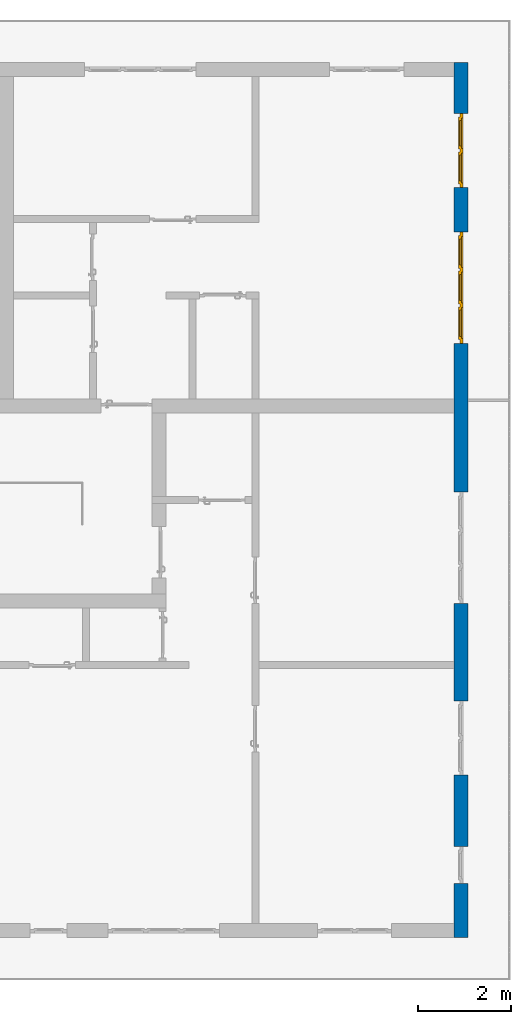
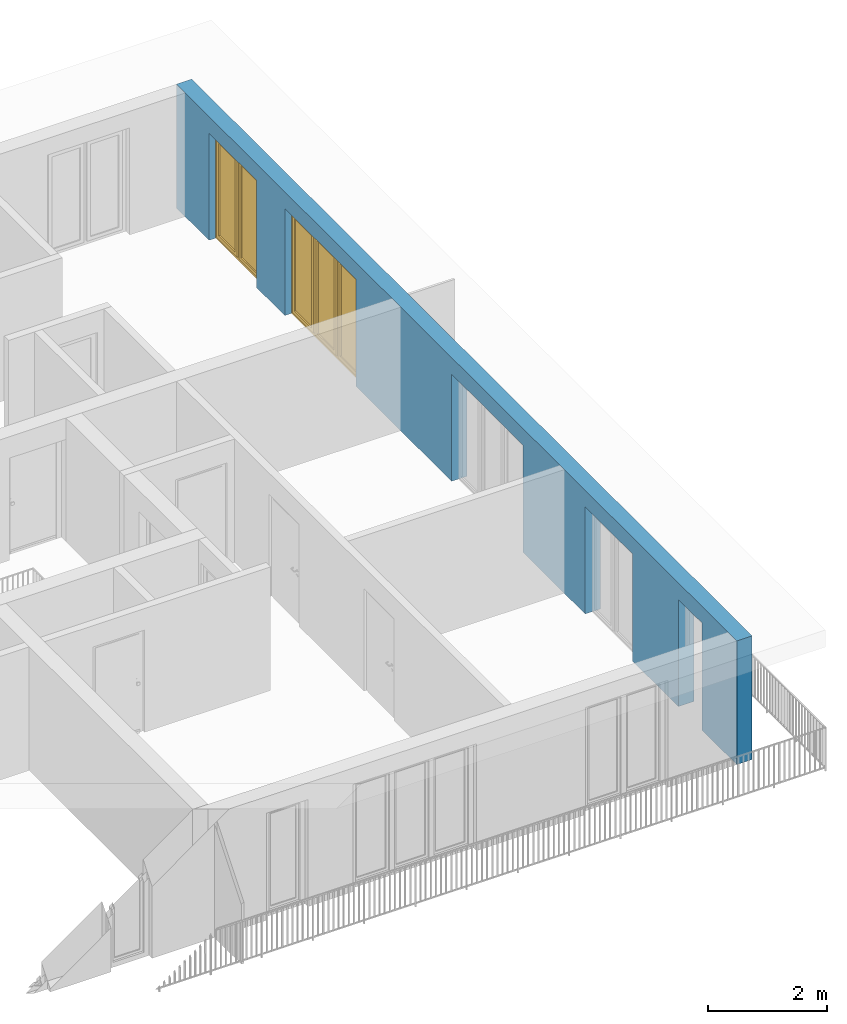
# One storey, part 21 of 54: 2 windows, 1 wall, 5 openings.
"""IFC4 building model written with IfcOpenShell, lengths in metres."""

import ifcopenshell
import ifcopenshell.guid

model = None  # the IFC model being written
_history = None  # IfcOwnerHistory: only IFC2X3 demands one
_inside = {}  # id of a spatial element -> (the spatial element, [elements in it])
_under = {}  # id of a project, library or spatial element -> (it, [spatial elements below it])
_declared = {}  # id of a project -> (the project, [libraries it declares])
_typed = {}  # id of a type object -> (the type object, [elements of that type])
_made_of = {}  # id of a material, layer set ... -> (it, [elements and type objects made of it])


def new_model(schema):
    """Start an empty IFC model of exactly this schema.

    Asked for "IFC4X3", IfcOpenShell would pick the latest addendum, in which some entities
    have other attributes; the version numbers below select the first issue.
    IFC2X3 requires an IfcOwnerHistory on every rooted entity: one is made here for all.
    """
    global model, _history
    if schema == "IFC4X3":
        model = ifcopenshell.file(schema_version=(4, 3, 0, 0))
    else:
        model = ifcopenshell.file(schema=schema)
    _inside.clear()
    _under.clear()
    _declared.clear()
    _typed.clear()
    _made_of.clear()
    _history = None
    if model.schema == "IFC2X3":
        org = make("IfcOrganization", Name="unknown")
        user = make(
            "IfcPersonAndOrganization",
            ThePerson=make("IfcPerson", FamilyName="unknown"),
            TheOrganization=org,
        )
        app = make(
            "IfcApplication",
            ApplicationDeveloper=org,
            Version="unknown",
            ApplicationFullName="unknown",
            ApplicationIdentifier="unknown",
        )
        _history = make(
            "IfcOwnerHistory",
            OwningUser=user,
            OwningApplication=app,
            ChangeAction="ADDED",
            CreationDate=0,
        )
    return model


def make(cls, **values):
    """One entity of the class cls with the attributes given. An attribute that is None is left unset."""
    return model.create_entity(
        cls, **{name: value for name, value in values.items() if value is not None}
    )


def entity(cls, *values):
    """Any entity or typed value of the class cls, its attributes in the order of the schema. None: left unset."""
    e = model.create_entity(cls)
    for i, value in enumerate(values):
        if value is not None:
            e[i] = value
    return e


def rooted(cls, **values):
    """An entity with a GlobalId (a new one), such as an element, a storey or a relation."""
    return make(cls, GlobalId=ifcopenshell.guid.new(), OwnerHistory=_history, **values)


def si_unit(unit_type, name, prefix=None):
    """IfcSIUnit, for example si_unit("LENGTHUNIT", "METRE", prefix="MILLI")."""
    return make("IfcSIUnit", UnitType=unit_type, Prefix=prefix, Name=name)


def converted_unit(unit_type, name, factor, base, dimensions=None, offset=None):
    """IfcConversionBasedUnit, such as the inch: factor (a typed value) times the base unit."""
    return make(
        "IfcConversionBasedUnit"
        if offset is None
        else "IfcConversionBasedUnitWithOffset",
        ConversionOffset=offset,
        Dimensions=None
        if dimensions is None
        else entity("IfcDimensionalExponents", *dimensions),
        UnitType=unit_type,
        Name=name,
        ConversionFactor=make(
            "IfcMeasureWithUnit", ValueComponent=factor, UnitComponent=base
        ),
    )


def derived_unit(unit_type, elements):
    """IfcDerivedUnit: a product of units, each with its exponent."""
    return make(
        "IfcDerivedUnit",
        Elements=[
            make("IfcDerivedUnitElement", Unit=unit, Exponent=power)
            for unit, power in elements
        ],
        UnitType=unit_type,
    )


def assignment(units):
    """IfcUnitAssignment: the units of a project."""
    return None if units is None else make("IfcUnitAssignment", Units=units)


def point(xyz):
    """IfcCartesianPoint."""
    return None if xyz is None else make("IfcCartesianPoint", Coordinates=xyz)


def direction(xyz):
    """IfcDirection."""
    return None if xyz is None else make("IfcDirection", DirectionRatios=xyz)


def frame(location, z_axis=None, x_axis=None):
    """IfcAxis2Placement3D, a coordinate frame: its origin and axes. An axis left out is left unset."""
    return make(
        "IfcAxis2Placement3D",
        Location=point(location),
        Axis=direction(z_axis),
        RefDirection=direction(x_axis),
    )


def origin_with_axes():
    """The frame at (0, 0, 0) with the z axis (0, 0, 1) and the x axis (1, 0, 0) written out."""
    return frame((0.0, 0.0, 0.0), z_axis=(0.0, 0.0, 1.0), x_axis=(1.0, 0.0, 0.0))


def place(relative_to, where):
    """IfcLocalPlacement: puts the frame where relative to a parent placement (None: the world)."""
    return make(
        "IfcLocalPlacement", PlacementRelTo=relative_to, RelativePlacement=where
    )


def context(
    kind, dimensions, precision=None, world=None, true_north=None, identifier=None
):
    """IfcGeometricRepresentationContext, for example the 3D "Model" context."""
    return make(
        "IfcGeometricRepresentationContext",
        ContextIdentifier=identifier,
        ContextType=kind,
        CoordinateSpaceDimension=dimensions,
        Precision=precision,
        WorldCoordinateSystem=world,
        TrueNorth=true_north,
    )


def subcontext(parent, identifier, kind, view, scale=None):
    """IfcGeometricRepresentationSubContext, for example "Body" below "Model"."""
    return make(
        "IfcGeometricRepresentationSubContext",
        ContextIdentifier=identifier,
        ContextType=kind,
        ParentContext=parent,
        TargetScale=scale,
        TargetView=view,
    )


def project(units=None, contexts=None):
    """IfcProject with its units and contexts."""
    return rooted(
        "IfcProject",
        Name="project",
        RepresentationContexts=contexts,
        UnitsInContext=assignment(units),
    )


def spatial(cls, under=None, at=None, **own):
    """A site, building, storey or space (cls), placed at a placement, below another one or the project."""
    s = rooted(cls, ObjectPlacement=at, **own)
    if under is not None:
        _under.setdefault(under.id(), (under, []))[1].append(s)
    return s


def point_list(points):
    """IfcCartesianPointList2D or 3D."""
    cls = (
        "IfcCartesianPointList2D" if len(points[0]) == 2 else "IfcCartesianPointList3D"
    )
    return make(cls, CoordList=points)


def polygons(points, faces, closed=None, point_numbers=None):
    """IfcPolygonalFaceSet: a face is its outer loop, then its inner loops; points numbered from 1."""
    made = []
    for loops in faces:
        if len(loops) == 1:
            made.append(make("IfcIndexedPolygonalFace", CoordIndex=loops[0]))
        else:
            made.append(
                make(
                    "IfcIndexedPolygonalFaceWithVoids",
                    CoordIndex=loops[0],
                    InnerCoordIndices=loops[1:],
                )
            )
    return make(
        "IfcPolygonalFaceSet",
        Coordinates=point_list(points),
        Closed=closed,
        Faces=made,
        PnIndex=point_numbers,
    )


def shape(context_of_items, identifier, shape_type, items):
    """IfcShapeRepresentation: the items that make up one representation, for example the "Body"."""
    return make(
        "IfcShapeRepresentation",
        ContextOfItems=context_of_items,
        RepresentationIdentifier=identifier,
        RepresentationType=shape_type,
        Items=items,
    )


def source(mapping_origin, context_of_items, identifier, shape_type, items):
    """IfcRepresentationMap: a shape defined once, which mapped items show again and again."""
    return make(
        "IfcRepresentationMap",
        MappingOrigin=mapping_origin,
        MappedRepresentation=shape(context_of_items, identifier, shape_type, items),
    )


def transform(
    local_origin,
    x_axis=None,
    y_axis=None,
    z_axis=None,
    scale=None,
    scale2=None,
    scale3=None,
    uniform=True,
):
    """IfcCartesianTransformationOperator3D, or its non-uniform kind. x_axis, y_axis, z_axis: its Axis1, 2, 3."""
    if uniform:
        return make(
            "IfcCartesianTransformationOperator3D",
            Axis1=direction(x_axis),
            Axis2=direction(y_axis),
            LocalOrigin=point(local_origin),
            Scale=scale,
            Axis3=direction(z_axis),
        )
    return make(
        "IfcCartesianTransformationOperator3DnonUniform",
        Axis1=direction(x_axis),
        Axis2=direction(y_axis),
        LocalOrigin=point(local_origin),
        Scale=scale,
        Axis3=direction(z_axis),
        Scale2=scale2,
        Scale3=scale3,
    )


def mapped(mapping_source, mapping_target):
    """IfcMappedItem: shows the shape of a source again, moved by a transform."""
    return make(
        "IfcMappedItem", MappingSource=mapping_source, MappingTarget=mapping_target
    )


def material(Name=None, Category=None):
    """IfcMaterial."""
    return make("IfcMaterial", Name=Name, Category=Category)


def made_of(thing, what):
    """Note that an element or type object is made of a material, layer set ...; save() writes the relation."""
    if what is not None:
        _made_of.setdefault(what.id(), (what, []))[1].append(thing)
    return thing


def type_object(cls, material=None, **own):
    """A type object (cls), such as IfcWallType, which elements share."""
    return made_of(rooted(cls, **own), material)


def element(
    cls,
    number,
    at=None,
    inside=None,
    cuts=None,
    type_object=None,
    material=None,
    context=None,
    identifier="Body",
    shape_type=None,
    held_by="IfcProductDefinitionShape",
    body=None,
    shapes=None,
    **own,
):
    """One element of the class cls, such as IfcWall. Its Tag is "e" and its number.

    at: its placement. inside: the storey or other place that contains it. cuts: it is an
    opening in that element (IfcRelVoidsElement). A single representation is given by context,
    identifier, shape_type and body (its items); several are given by shapes. held_by: the class
    of the entity that holds the representations. save() writes the other relations.
    """
    e = rooted(cls, Tag="e%d" % number, ObjectPlacement=at, **own)
    if body is not None:
        shapes = [shape(context, identifier, shape_type, body)]
    if shapes is not None:
        e.Representation = make(held_by, Representations=shapes)
    if inside is not None:
        _inside.setdefault(inside.id(), (inside, []))[1].append(e)
    if cuts is not None:
        rooted(
            "IfcRelVoidsElement", RelatingBuildingElement=cuts, RelatedOpeningElement=e
        )
    if type_object is not None:
        _typed.setdefault(type_object.id(), (type_object, []))[1].append(e)
    return made_of(e, material)


def fill(opening, filler):
    """IfcRelFillsElement: the door or window that sits in an opening."""
    return rooted(
        "IfcRelFillsElement",
        RelatingOpeningElement=opening,
        RelatedBuildingElement=filler,
    )


def aggregate(whole, parts):
    """IfcRelAggregates: a whole, such as a stair, and the parts it consists of."""
    return rooted("IfcRelAggregates", RelatingObject=whole, RelatedObjects=parts)


def save(model, path):
    """Write the relations noted so far, then the file.

    IfcRelAggregates (storeys below a building ...), IfcRelContainedInSpatialStructure (elements
    in a storey), IfcRelDefinesByType, IfcRelAssociatesMaterial and IfcRelDeclares: one each for
    every whole, place, type object, material and project.
    """
    for whole, parts in _under.values():
        aggregate(whole, parts)
    for where, things in _inside.values():
        rooted(
            "IfcRelContainedInSpatialStructure",
            RelatedElements=things,
            RelatingStructure=where,
        )
    for kind, things in _typed.values():
        rooted("IfcRelDefinesByType", RelatedObjects=things, RelatingType=kind)
    for what, things in _made_of.values():
        rooted("IfcRelAssociatesMaterial", RelatedObjects=things, RelatingMaterial=what)
    for by, libraries in _declared.values():
        rooted("IfcRelDeclares", RelatingContext=by, RelatedDefinitions=libraries)
    model.write(path)


model = new_model("IFC4")

# Units and contexts
model_context = context("Model", 3, precision=1e-05, world=origin_with_axes(), true_north=direction((0.0, 1.0)))
body_context = subcontext(model_context, "Body", "Model", "MODEL_VIEW")
ifc_project = project(units=[si_unit("LENGTHUNIT", "METRE"), si_unit("AREAUNIT", "SQUARE_METRE"), si_unit("VOLUMEUNIT", "CUBIC_METRE"), converted_unit("PLANEANGLEUNIT", "DEGREE", entity("IfcPlaneAngleMeasure", 0.0174532925199), si_unit("PLANEANGLEUNIT", "RADIAN"), dimensions=[0, 0, 0, 0, 0, 0, 0]), converted_unit("TIMEUNIT", "Year", entity("IfcTimeMeasure", 31556926.0), si_unit("TIMEUNIT", "SECOND"), dimensions=[0, 0, 1, 0, 0, 0, 0]), si_unit("MASSUNIT", "GRAM", prefix="KILO"), si_unit("THERMODYNAMICTEMPERATUREUNIT", "DEGREE_CELSIUS"), si_unit("LUMINOUSINTENSITYUNIT", "LUMEN"), si_unit("ENERGYUNIT", "JOULE", prefix="MEGA"), derived_unit("THERMALCONDUCTANCEUNIT", [(si_unit("POWERUNIT", "WATT"), 1), (si_unit("LENGTHUNIT", "METRE"), -1), (si_unit("THERMODYNAMICTEMPERATUREUNIT", "KELVIN"), -1)]), derived_unit("SPECIFICHEATCAPACITYUNIT", [(si_unit("ENERGYUNIT", "JOULE"), 1), (si_unit("MASSUNIT", "GRAM", prefix="KILO"), -1), (si_unit("THERMODYNAMICTEMPERATUREUNIT", "KELVIN"), -1)]), derived_unit("MASSDENSITYUNIT", [(si_unit("MASSUNIT", "GRAM", prefix="KILO"), 1), (si_unit("VOLUMEUNIT", "CUBIC_METRE"), -1)])], contexts=[model_context])

# Site, building, storey
site_placement = place(None, origin_with_axes())
site = spatial("IfcSite", under=ifc_project, at=site_placement, CompositionType="ELEMENT")
building_placement = place(site_placement, origin_with_axes())
building = spatial("IfcBuilding", under=site, at=building_placement, CompositionType="ELEMENT")
storey_placement = place(building_placement, frame((0.0, 0.0, 9.18), z_axis=(0.0, 0.0, 1.0), x_axis=(1.0, 0.0, 0.0)))
storey = spatial("IfcBuildingStorey", under=building, at=storey_placement, Name="3. Geschoss", CompositionType="ELEMENT", Elevation=9.18)

# Wall, openings, windows
ifc_material = material()
wall_type = type_object("IfcWallType", Name="300", PredefinedType="NOTDEFINED")
wall_placement = place(storey_placement, frame((9.3378006196, -9.92881223104, 0.0), z_axis=(0.0, 0.0, 1.0), x_axis=(0.0, 1.0, 0.0)))
wall = element("IfcWall", 1, at=wall_placement, inside=storey, type_object=wall_type, material=ifc_material, Name="Wand-001", PredefinedType="NOTDEFINED", context=body_context, shape_type="Tessellation", body=[
    polygons([(1.16441876325, 0.1, 2.2), (1.96441876325, 0.1, 2.2), (1.96441876325, 0.0, 2.2), (1.16441876325, 0.0, 2.2), (1.16441876325, 0.3, 2.2), (1.96441876325, 0.3, 2.2), (1.96441876325, 0.1, 0.0), (1.96441876325, 0.0, 0.0), (18.85, 0.0, 2.54), (0.0, 0.0, 2.54), (0.0, 0.0, 0.0), (1.16441876325, 0.0, 0.0), (3.5, 0.0, 0.0), (3.5, 0.0, 2.2), (5.1, 0.0, 2.2), (5.1, 0.0, 0.0), (7.1921181063, 0.0, 0.0), (7.1921181063, 0.0, 2.2), (9.5921181063, 0.0, 2.2), (9.5921181063, 0.0, 0.0), (12.8, 0.0, 0.0), (12.8, 0.0, 2.2), (15.2, 0.0, 2.2), (15.2, 0.0, 0.0), (16.15, 0.0, 0.0), (16.15, 0.0, 2.2), (17.75, 0.0, 2.2), (17.75, 0.0, 0.0), (18.85, 0.0, 0.0), (1.16441876325, 0.1, 0.0), (1.16441876325, 0.3, 0.0), (0.0, 0.3, 0.0), (0.0, 0.3, 2.54), (18.85, 0.3, 2.54), (18.85, 0.3, 0.0), (17.75, 0.3, 0.0), (17.75, 0.3, 2.2), (16.15, 0.3, 2.2), (16.15, 0.3, 0.0), (15.2, 0.3, 0.0), (15.2, 0.3, 2.2), (12.8, 0.3, 2.2), (12.8, 0.3, 0.0), (9.5921181063, 0.3, 0.0), (9.5921181063, 0.3, 2.2), (7.1921181063, 0.3, 2.2), (7.1921181063, 0.3, 0.0), (5.1, 0.3, 0.0), (5.1, 0.3, 2.2), (3.5, 0.3, 2.2), (3.5, 0.3, 0.0), (1.96441876325, 0.3, 0.0), (3.5, 0.1, 0.0), (3.5, 0.1, 2.2), (5.1, 0.1, 2.2), (5.1, 0.1, 0.0), (7.1921181063, 0.1, 0.0), (7.1921181063, 0.1, 2.2), (9.5921181063, 0.1, 2.2), (9.5921181063, 0.1, 0.0), (12.8, 0.1, 0.0), (12.8, 0.1, 2.2), (15.2, 0.1, 2.2), (15.2, 0.1, 0.0), (16.15, 0.1, 0.0), (16.15, 0.1, 2.2), (17.75, 0.1, 2.2), (17.75, 0.1, 0.0)], [[[1, 2, 3, 4]], [[2, 1, 5, 6]], [[2, 7, 8, 3]], [[9, 10, 11, 12, 4, 3, 8, 13, 14, 15, 16, 17, 18, 19, 20, 21, 22, 23, 24, 25, 26, 27, 28, 29]], [[30, 1, 4, 12]], [[1, 30, 31, 5]], [[5, 31, 32, 33, 34, 35, 36, 37, 38, 39, 40, 41, 42, 43, 44, 45, 46, 47, 48, 49, 50, 51, 52, 6]], [[7, 2, 6, 52]], [[7, 52, 51, 53, 13, 8]], [[9, 34, 33, 10]], [[33, 32, 11, 10]], [[31, 30, 12, 11, 32]], [[14, 13, 53, 54]], [[15, 14, 54, 55]], [[16, 15, 55, 56]], [[56, 48, 47, 57, 17, 16]], [[57, 58, 18, 17]], [[58, 59, 19, 18]], [[59, 60, 20, 19]], [[60, 44, 43, 61, 21, 20]], [[22, 21, 61, 62]], [[23, 22, 62, 63]], [[24, 23, 63, 64]], [[64, 40, 39, 65, 25, 24]], [[65, 66, 26, 25]], [[66, 67, 27, 26]], [[67, 68, 28, 27]], [[36, 35, 29, 28, 68]], [[9, 29, 35, 34]], [[68, 67, 37, 36]], [[67, 66, 38, 37]], [[66, 65, 39, 38]], [[41, 40, 64, 63]], [[42, 41, 63, 62]], [[43, 42, 62, 61]], [[60, 59, 45, 44]], [[59, 58, 46, 45]], [[58, 57, 47, 46]], [[49, 48, 56, 55]], [[50, 49, 55, 54]], [[51, 50, 54, 53]]], closed=True),
])
opening_1_placement = place(wall_placement, frame((16.95, 0.0, 0.0), z_axis=(0.0, 0.0, 1.0), x_axis=(1.0, 0.0, 0.0)))
opening_1 = element("IfcOpeningElement", 2, at=opening_1_placement, cuts=wall, Name="Fenster-001", context=body_context, identifier="Reference", shape_type="Tessellation", body=[
    polygons([(0.8, 0.1, 0.0), (0.8, 0.1, 2.2), (0.8, -0.000999999999999, 2.2), (0.8, -0.000999999999999, 0.0), (0.8, 0.301, 0.0), (0.8, 0.301, 2.2), (-0.8, 0.1, 2.2), (-0.8, -0.000999999999999, 2.2), (-0.8, 0.301, 2.2), (-0.8, -0.000999999999999, 0.0), (-0.8, 0.1, 0.0), (-0.8, 0.301, 0.0)], [[[1, 2, 3, 4]], [[2, 1, 5, 6]], [[7, 8, 3, 2, 6, 9]], [[8, 10, 4, 3]], [[1, 4, 10, 11, 12, 5]], [[6, 5, 12, 9]], [[7, 11, 10, 8]], [[11, 7, 9, 12]]], closed=True),
])
opening_2_placement = place(wall_placement, frame((14.0, 0.0, 0.0), z_axis=(0.0, 0.0, 1.0), x_axis=(1.0, 0.0, 0.0)))
opening_2 = element("IfcOpeningElement", 3, at=opening_2_placement, cuts=wall, Name="Fenster-002", context=body_context, identifier="Reference", shape_type="Tessellation", body=[
    polygons([(1.2, 0.1, 0.0), (1.2, 0.1, 2.2), (1.2, -0.000999999999999, 2.2), (1.2, -0.000999999999999, 0.0), (1.2, 0.301, 0.0), (1.2, 0.301, 2.2), (-1.2, 0.1, 2.2), (-1.2, -0.000999999999999, 2.2), (-1.2, 0.301, 2.2), (-1.2, -0.000999999999999, 0.0), (-1.2, 0.1, 0.0), (-1.2, 0.301, 0.0)], [[[1, 2, 3, 4]], [[2, 1, 5, 6]], [[7, 8, 3, 2, 6, 9]], [[8, 10, 4, 3]], [[1, 4, 10, 11, 12, 5]], [[6, 5, 12, 9]], [[7, 11, 10, 8]], [[11, 7, 9, 12]]], closed=True),
])
opening_3_placement = place(wall_placement, frame((8.3921181063, 0.0, 0.0), z_axis=(0.0, 0.0, 1.0), x_axis=(1.0, 0.0, 0.0)))
element("IfcOpeningElement", 4, at=opening_3_placement, cuts=wall, Name="Fenster-002", context=body_context, identifier="Reference", shape_type="Tessellation", body=[
    polygons([(1.2, 0.1, 0.0), (1.2, 0.1, 2.2), (1.2, -0.000999999999999, 2.2), (1.2, -0.000999999999999, 0.0), (1.2, 0.301, 0.0), (1.2, 0.301, 2.2), (-1.2, 0.1, 2.2), (-1.2, -0.000999999999999, 2.2), (-1.2, 0.301, 2.2), (-1.2, -0.000999999999999, 0.0), (-1.2, 0.1, 0.0), (-1.2, 0.301, 0.0)], [[[1, 2, 3, 4]], [[2, 1, 5, 6]], [[7, 8, 3, 2, 6, 9]], [[8, 10, 4, 3]], [[1, 4, 10, 11, 12, 5]], [[6, 5, 12, 9]], [[7, 11, 10, 8]], [[11, 7, 9, 12]]], closed=True),
])
opening_4_placement = place(wall_placement, frame((4.3, 0.0, 0.0), z_axis=(0.0, 0.0, 1.0), x_axis=(1.0, 0.0, 0.0)))
element("IfcOpeningElement", 5, at=opening_4_placement, cuts=wall, Name="Fenster-001", context=body_context, identifier="Reference", shape_type="Tessellation", body=[
    polygons([(0.8, 0.1, 0.0), (0.8, 0.1, 2.2), (0.8, -0.000999999999999, 2.2), (0.8, -0.000999999999999, 0.0), (0.8, 0.301, 0.0), (0.8, 0.301, 2.2), (-0.8, 0.1, 2.2), (-0.8, -0.000999999999999, 2.2), (-0.8, 0.301, 2.2), (-0.8, -0.000999999999999, 0.0), (-0.8, 0.1, 0.0), (-0.8, 0.301, 0.0)], [[[1, 2, 3, 4]], [[2, 1, 5, 6]], [[7, 8, 3, 2, 6, 9]], [[8, 10, 4, 3]], [[1, 4, 10, 11, 12, 5]], [[6, 5, 12, 9]], [[7, 11, 10, 8]], [[11, 7, 9, 12]]], closed=True),
])
opening_5_placement = place(wall_placement, frame((1.56441876325, 0.0, 0.0), z_axis=(0.0, 0.0, 1.0), x_axis=(1.0, 0.0, 0.0)))
element("IfcOpeningElement", 6, at=opening_5_placement, cuts=wall, Name="Fenster-003", context=body_context, identifier="Reference", shape_type="Tessellation", body=[
    polygons([(0.4, 0.1, 0.0), (0.4, 0.1, 2.2), (0.4, -0.000999999999999, 2.2), (0.4, -0.000999999999999, 0.0), (0.4, 0.301, 0.0), (0.4, 0.301, 2.2), (-0.4, 0.1, 2.2), (-0.4, -0.000999999999999, 2.2), (-0.4, 0.301, 2.2), (-0.4, -0.000999999999999, 0.0), (-0.4, 0.1, 0.0), (-0.4, 0.301, 0.0)], [[[1, 2, 3, 4]], [[2, 1, 5, 6]], [[7, 8, 3, 2, 6, 9]], [[8, 10, 4, 3]], [[1, 4, 10, 11, 12, 5]], [[6, 5, 12, 9]], [[7, 11, 10, 8]], [[11, 7, 9, 12]]], closed=True),
])
window_type_1 = type_object("IfcWindowType", Name="2-1+1 26", PartitioningType="DOUBLE_PANEL_VERTICAL", PredefinedType="WINDOW")
shared_shape_1 = source(origin_with_axes(), body_context, "Body", "Tessellation", [
    polygons([(-0.8, -0.07, 0.0), (-0.8, 0.0, 0.0), (-0.7, 0.0, 0.1), (-0.7, -0.07, 0.1), (-0.8, -0.07, 2.2), (-0.8, 0.0, 2.2), (-0.7, 0.0, 2.1), (-0.7, -0.07, 2.1)], [[[1, 2, 3, 4]], [[5, 6, 2, 1]], [[2, 6, 7, 3]], [[4, 3, 7, 8]], [[1, 4, 8, 5]], [[8, 7, 6, 5]]], closed=True),
    polygons([(0.8, -0.07, 0.0), (0.8, 0.0, 0.0), (0.8, 0.0, 2.2), (0.8, -0.07, 2.2), (0.7, -0.07, 0.1), (0.7, 0.0, 0.1), (0.7, 0.0, 2.1), (0.7, -0.07, 2.1)], [[[1, 2, 3, 4]], [[5, 6, 2, 1]], [[2, 6, 7, 3]], [[4, 3, 7, 8]], [[1, 4, 8, 5]], [[8, 7, 6, 5]]], closed=True),
    polygons([(-0.8, -0.07, 0.0), (-0.8, 0.0, 0.0), (0.8, 0.0, 0.0), (0.8, -0.07, 0.0), (-0.7, -0.07, 0.1), (-0.7, 0.0, 0.1), (-0.05, 0.0, 0.1), (0.05, 0.0, 0.1), (0.7, 0.0, 0.1), (0.7, -0.07, 0.1), (0.05, -0.07, 0.1), (-0.05, -0.07, 0.1)], [[[1, 2, 3, 4]], [[5, 6, 2, 1]], [[2, 6, 7, 8, 9, 3]], [[4, 3, 9, 10]], [[1, 4, 10, 11, 12, 5]], [[12, 7, 6, 5]], [[11, 8, 7, 12]], [[10, 9, 8, 11]]], closed=True),
    polygons([(-0.8, -0.07, 2.2), (-0.8, 0.0, 2.2), (-0.7, 0.0, 2.1), (-0.7, -0.07, 2.1), (0.8, -0.07, 2.2), (0.8, 0.0, 2.2), (0.7, 0.0, 2.1), (0.05, 0.0, 2.1), (-0.05, 0.0, 2.1), (-0.05, -0.07, 2.1), (0.05, -0.07, 2.1), (0.7, -0.07, 2.1)], [[[1, 2, 3, 4]], [[5, 6, 2, 1]], [[2, 6, 7, 8, 9, 3]], [[4, 3, 9, 10]], [[1, 4, 10, 11, 12, 5]], [[12, 7, 6, 5]], [[11, 8, 7, 12]], [[10, 9, 8, 11]]], closed=True),
    polygons([(-0.05, -0.07, 0.1), (-0.05, 0.0, 0.1), (0.05, 0.0, 0.1), (0.05, -0.07, 0.1), (-0.05, -0.07, 2.1), (-0.05, 0.0, 2.1), (0.05, 0.0, 2.1), (0.05, -0.07, 2.1)], [[[1, 2, 3, 4]], [[5, 6, 2, 1]], [[2, 6, 7, 3]], [[4, 3, 7, 8]], [[1, 4, 8, 5]], [[8, 7, 6, 5]]], closed=True),
    polygons([(-0.72, 0.0, 0.08), (-0.72, 0.03, 0.08), (-0.65, 0.03, 0.15), (-0.65, 0.0, 0.15), (-0.72, 0.0, 2.12), (-0.72, 0.03, 2.12), (-0.65, 0.03, 2.05), (-0.65, 0.0, 2.05)], [[[1, 2, 3, 4]], [[5, 6, 2, 1]], [[2, 6, 7, 3]], [[4, 3, 7, 8]], [[1, 4, 8, 5]], [[8, 7, 6, 5]]], closed=True),
    polygons([(-0.03, 0.0, 0.08), (-0.1, 0.0, 0.15), (-0.1, 0.03, 0.15), (-0.03, 0.03, 0.08), (-0.03, 0.0, 2.12), (-0.1, 0.0, 2.05), (-0.1, 0.03, 2.05), (-0.03, 0.03, 2.12)], [[[1, 2, 3, 4]], [[1, 5, 6, 2]], [[2, 6, 7, 3]], [[4, 3, 7, 8]], [[5, 1, 4, 8]], [[6, 5, 8, 7]]], closed=True),
    polygons([(-0.72, 0.0, 0.08), (-0.72, 0.03, 0.08), (-0.03, 0.03, 0.08), (-0.03, 0.0, 0.08), (-0.65, 0.0, 0.15), (-0.65, 0.03, 0.15), (-0.1, 0.03, 0.15), (-0.1, 0.0, 0.15)], [[[1, 2, 3, 4]], [[5, 6, 2, 1]], [[2, 6, 7, 3]], [[4, 3, 7, 8]], [[1, 4, 8, 5]], [[8, 7, 6, 5]]], closed=True),
    polygons([(-0.72, 0.0, 2.12), (-0.03, 0.0, 2.12), (-0.03, 0.03, 2.12), (-0.72, 0.03, 2.12), (-0.65, 0.0, 2.05), (-0.1, 0.0, 2.05), (-0.1, 0.03, 2.05), (-0.65, 0.03, 2.05)], [[[1, 2, 3, 4]], [[1, 5, 6, 2]], [[2, 6, 7, 3]], [[4, 3, 7, 8]], [[5, 1, 4, 8]], [[6, 5, 8, 7]]], closed=True),
    polygons([(-0.7, -0.03, 0.1), (-0.7, 0.0, 0.1), (-0.65, 0.0, 0.15), (-0.65, -0.03, 0.15), (-0.7, -0.03, 2.1), (-0.7, 0.0, 2.1), (-0.65, 0.0, 2.05), (-0.65, -0.03, 2.05)], [[[1, 2, 3, 4]], [[5, 6, 2, 1]], [[2, 6, 7, 3]], [[4, 3, 7, 8]], [[1, 4, 8, 5]], [[8, 7, 6, 5]]], closed=True),
    polygons([(-0.05, -0.03, 0.1), (-0.1, -0.03, 0.15), (-0.1, 0.0, 0.15), (-0.05, 0.0, 0.1), (-0.05, -0.03, 2.1), (-0.1, -0.03, 2.05), (-0.1, 0.0, 2.05), (-0.05, 0.0, 2.1)], [[[1, 2, 3, 4]], [[1, 5, 6, 2]], [[2, 6, 7, 3]], [[4, 3, 7, 8]], [[5, 1, 4, 8]], [[6, 5, 8, 7]]], closed=True),
    polygons([(-0.7, -0.03, 0.1), (-0.7, 0.0, 0.1), (-0.05, 0.0, 0.1), (-0.05, -0.03, 0.1), (-0.65, -0.03, 0.15), (-0.65, 0.0, 0.15), (-0.1, 0.0, 0.15), (-0.1, -0.03, 0.15)], [[[1, 2, 3, 4]], [[5, 6, 2, 1]], [[2, 6, 7, 3]], [[4, 3, 7, 8]], [[1, 4, 8, 5]], [[8, 7, 6, 5]]], closed=True),
    polygons([(-0.7, -0.03, 2.1), (-0.05, -0.03, 2.1), (-0.05, 0.0, 2.1), (-0.7, 0.0, 2.1), (-0.65, -0.03, 2.05), (-0.1, -0.03, 2.05), (-0.1, 0.0, 2.05), (-0.65, 0.0, 2.05)], [[[1, 2, 3, 4]], [[1, 5, 6, 2]], [[2, 6, 7, 3]], [[4, 3, 7, 8]], [[5, 1, 4, 8]], [[6, 5, 8, 7]]], closed=True),
    polygons([(-0.65, -0.005, 0.15), (-0.65, 0.005, 0.15), (-0.1, 0.005, 0.15), (-0.1, -0.005, 0.15), (-0.65, -0.005, 2.05), (-0.65, 0.005, 2.05), (-0.1, 0.005, 2.05), (-0.1, -0.005, 2.05)], [[[1, 2, 3, 4]], [[5, 6, 2, 1]], [[2, 6, 7, 3]], [[4, 3, 7, 8]], [[1, 4, 8, 5]], [[8, 7, 6, 5]]], closed=True),
    polygons([(0.03, 0.0, 0.08), (0.03, 0.03, 0.08), (0.1, 0.03, 0.15), (0.1, 0.0, 0.15), (0.03, 0.0, 2.12), (0.03, 0.03, 2.12), (0.1, 0.03, 2.05), (0.1, 0.0, 2.05)], [[[1, 2, 3, 4]], [[5, 6, 2, 1]], [[2, 6, 7, 3]], [[4, 3, 7, 8]], [[1, 4, 8, 5]], [[8, 7, 6, 5]]], closed=True),
    polygons([(0.72, 0.0, 0.08), (0.65, 0.0, 0.15), (0.65, 0.03, 0.15), (0.72, 0.03, 0.08), (0.72, 0.0, 2.12), (0.65, 0.0, 2.05), (0.65, 0.03, 2.05), (0.72, 0.03, 2.12)], [[[1, 2, 3, 4]], [[1, 5, 6, 2]], [[2, 6, 7, 3]], [[4, 3, 7, 8]], [[5, 1, 4, 8]], [[6, 5, 8, 7]]], closed=True),
    polygons([(0.03, 0.0, 0.08), (0.03, 0.03, 0.08), (0.72, 0.03, 0.08), (0.72, 0.0, 0.08), (0.1, 0.0, 0.15), (0.1, 0.03, 0.15), (0.65, 0.03, 0.15), (0.65, 0.0, 0.15)], [[[1, 2, 3, 4]], [[5, 6, 2, 1]], [[2, 6, 7, 3]], [[4, 3, 7, 8]], [[1, 4, 8, 5]], [[8, 7, 6, 5]]], closed=True),
    polygons([(0.03, 0.0, 2.12), (0.72, 0.0, 2.12), (0.72, 0.03, 2.12), (0.03, 0.03, 2.12), (0.1, 0.0, 2.05), (0.65, 0.0, 2.05), (0.65, 0.03, 2.05), (0.1, 0.03, 2.05)], [[[1, 2, 3, 4]], [[1, 5, 6, 2]], [[2, 6, 7, 3]], [[4, 3, 7, 8]], [[5, 1, 4, 8]], [[6, 5, 8, 7]]], closed=True),
    polygons([(0.05, -0.03, 0.1), (0.05, 0.0, 0.1), (0.1, 0.0, 0.15), (0.1, -0.03, 0.15), (0.05, -0.03, 2.1), (0.05, 0.0, 2.1), (0.1, 0.0, 2.05), (0.1, -0.03, 2.05)], [[[1, 2, 3, 4]], [[5, 6, 2, 1]], [[2, 6, 7, 3]], [[4, 3, 7, 8]], [[1, 4, 8, 5]], [[8, 7, 6, 5]]], closed=True),
    polygons([(0.7, -0.03, 0.1), (0.65, -0.03, 0.15), (0.65, 0.0, 0.15), (0.7, 0.0, 0.1), (0.7, -0.03, 2.1), (0.65, -0.03, 2.05), (0.65, 0.0, 2.05), (0.7, 0.0, 2.1)], [[[1, 2, 3, 4]], [[1, 5, 6, 2]], [[2, 6, 7, 3]], [[4, 3, 7, 8]], [[5, 1, 4, 8]], [[6, 5, 8, 7]]], closed=True),
    polygons([(0.05, -0.03, 0.1), (0.05, 0.0, 0.1), (0.7, 0.0, 0.1), (0.7, -0.03, 0.1), (0.1, -0.03, 0.15), (0.1, 0.0, 0.15), (0.65, 0.0, 0.15), (0.65, -0.03, 0.15)], [[[1, 2, 3, 4]], [[5, 6, 2, 1]], [[2, 6, 7, 3]], [[4, 3, 7, 8]], [[1, 4, 8, 5]], [[8, 7, 6, 5]]], closed=True),
    polygons([(0.05, -0.03, 2.1), (0.7, -0.03, 2.1), (0.7, 0.0, 2.1), (0.05, 0.0, 2.1), (0.1, -0.03, 2.05), (0.65, -0.03, 2.05), (0.65, 0.0, 2.05), (0.1, 0.0, 2.05)], [[[1, 2, 3, 4]], [[1, 5, 6, 2]], [[2, 6, 7, 3]], [[4, 3, 7, 8]], [[5, 1, 4, 8]], [[6, 5, 8, 7]]], closed=True),
    polygons([(0.1, -0.005, 0.15), (0.1, 0.005, 0.15), (0.65, 0.005, 0.15), (0.65, -0.005, 0.15), (0.1, -0.005, 2.05), (0.1, 0.005, 2.05), (0.65, 0.005, 2.05), (0.65, -0.005, 2.05)], [[[1, 2, 3, 4]], [[5, 6, 2, 1]], [[2, 6, 7, 3]], [[4, 3, 7, 8]], [[1, 4, 8, 5]], [[8, 7, 6, 5]]], closed=True),
])
window_1_placement = place(opening_1_placement, frame((-0.8, 0.0, 0.0), z_axis=(0.0, 0.0, 1.0), x_axis=(1.0, 0.0, 0.0)))
window_1 = element("IfcWindow", 7, at=window_1_placement, inside=storey, type_object=window_type_1, Name="Fenster-001", OverallHeight=2.2, OverallWidth=1.6, PredefinedType="WINDOW", context=body_context, shape_type="MappedRepresentation", body=[
    mapped(shared_shape_1, transform((0.8, 0.17, 0.0))),
])
fill(opening_1, window_1)
window_type_2 = type_object("IfcWindowType", Name="3-1+1+1 26", PartitioningType="TRIPLE_PANEL_VERTICAL", PredefinedType="WINDOW")
shared_shape_2 = source(origin_with_axes(), body_context, "Body", "Tessellation", [
    polygons([(1.2, -0.07, 0.0), (1.1, -0.07, 0.1), (1.1, 0.0, 0.1), (1.2, 0.0, 0.0), (1.2, -0.07, 2.2), (1.1, -0.07, 2.1), (1.1, 0.0, 2.1), (1.2, 0.0, 2.2)], [[[1, 2, 3, 4]], [[1, 5, 6, 2]], [[2, 6, 7, 3]], [[4, 3, 7, 8]], [[5, 1, 4, 8]], [[6, 5, 8, 7]]], closed=True),
    polygons([(-1.2, -0.07, 0.0), (-1.2, -0.07, 2.2), (-1.2, 0.0, 2.2), (-1.2, 0.0, 0.0), (-1.1, -0.07, 0.1), (-1.1, -0.07, 2.1), (-1.1, 0.0, 2.1), (-1.1, 0.0, 0.1)], [[[1, 2, 3, 4]], [[1, 5, 6, 2]], [[2, 6, 7, 3]], [[4, 3, 7, 8]], [[5, 1, 4, 8]], [[6, 5, 8, 7]]], closed=True),
    polygons([(1.2, -0.07, 0.0), (-1.2, -0.07, 0.0), (-1.2, 0.0, 0.0), (1.2, 0.0, 0.0), (1.1, -0.07, 0.1), (0.433333333333, -0.07, 0.1), (0.333333333333, -0.07, 0.1), (-0.333333333333, -0.07, 0.1), (-0.433333333333, -0.07, 0.1), (-1.1, -0.07, 0.1), (-1.1, 0.0, 0.1), (-0.433333333333, 0.0, 0.1), (-0.333333333333, 0.0, 0.1), (0.333333333333, 0.0, 0.1), (0.433333333333, 0.0, 0.1), (1.1, 0.0, 0.1)], [[[1, 2, 3, 4]], [[1, 5, 6, 7, 8, 9, 10, 2]], [[2, 10, 11, 3]], [[4, 3, 11, 12, 13, 14, 15, 16]], [[5, 1, 4, 16]], [[6, 5, 16, 15]], [[7, 6, 15, 14]], [[8, 7, 14, 13]], [[9, 8, 13, 12]], [[10, 9, 12, 11]]], closed=True),
    polygons([(1.2, -0.07, 2.2), (1.1, -0.07, 2.1), (1.1, 0.0, 2.1), (1.2, 0.0, 2.2), (-1.2, -0.07, 2.2), (-1.1, -0.07, 2.1), (-0.433333333333, -0.07, 2.1), (-0.333333333333, -0.07, 2.1), (0.333333333333, -0.07, 2.1), (0.433333333333, -0.07, 2.1), (0.433333333333, 0.0, 2.1), (0.333333333333, 0.0, 2.1), (-0.333333333333, 0.0, 2.1), (-0.433333333333, 0.0, 2.1), (-1.1, 0.0, 2.1), (-1.2, 0.0, 2.2)], [[[1, 2, 3, 4]], [[1, 5, 6, 7, 8, 9, 10, 2]], [[2, 10, 11, 3]], [[4, 3, 11, 12, 13, 14, 15, 16]], [[5, 1, 4, 16]], [[6, 5, 16, 15]], [[7, 6, 15, 14]], [[8, 7, 14, 13]], [[9, 8, 13, 12]], [[10, 9, 12, 11]]], closed=True),
    polygons([(-0.333333333333, -0.07, 0.1), (-0.433333333333, -0.07, 0.1), (-0.433333333333, 0.0, 0.1), (-0.333333333333, 0.0, 0.1), (-0.333333333333, -0.07, 2.1), (-0.433333333333, -0.07, 2.1), (-0.433333333333, 0.0, 2.1), (-0.333333333333, 0.0, 2.1)], [[[1, 2, 3, 4]], [[1, 5, 6, 2]], [[2, 6, 7, 3]], [[4, 3, 7, 8]], [[5, 1, 4, 8]], [[6, 5, 8, 7]]], closed=True),
    polygons([(0.433333333333, -0.07, 0.1), (0.333333333333, -0.07, 0.1), (0.333333333333, 0.0, 0.1), (0.433333333333, 0.0, 0.1), (0.433333333333, -0.07, 2.1), (0.333333333333, -0.07, 2.1), (0.333333333333, 0.0, 2.1), (0.433333333333, 0.0, 2.1)], [[[1, 2, 3, 4]], [[1, 5, 6, 2]], [[2, 6, 7, 3]], [[4, 3, 7, 8]], [[5, 1, 4, 8]], [[6, 5, 8, 7]]], closed=True),
    polygons([(1.12, 0.0, 0.08), (1.05, 0.0, 0.15), (1.05, 0.03, 0.15), (1.12, 0.03, 0.08), (1.12, 0.0, 2.12), (1.05, 0.0, 2.05), (1.05, 0.03, 2.05), (1.12, 0.03, 2.12)], [[[1, 2, 3, 4]], [[1, 5, 6, 2]], [[2, 6, 7, 3]], [[4, 3, 7, 8]], [[5, 1, 4, 8]], [[6, 5, 8, 7]]], closed=True),
    polygons([(0.413333333333, 0.0, 0.08), (0.413333333333, 0.03, 0.08), (0.483333333333, 0.03, 0.15), (0.483333333333, 0.0, 0.15), (0.413333333333, 0.0, 2.12), (0.413333333333, 0.03, 2.12), (0.483333333333, 0.03, 2.05), (0.483333333333, 0.0, 2.05)], [[[1, 2, 3, 4]], [[5, 6, 2, 1]], [[2, 6, 7, 3]], [[4, 3, 7, 8]], [[1, 4, 8, 5]], [[8, 7, 6, 5]]], closed=True),
    polygons([(1.12, 0.0, 0.08), (0.413333333333, 0.0, 0.08), (0.413333333333, 0.03, 0.08), (1.12, 0.03, 0.08), (1.05, 0.0, 0.15), (0.483333333333, 0.0, 0.15), (0.483333333333, 0.03, 0.15), (1.05, 0.03, 0.15)], [[[1, 2, 3, 4]], [[1, 5, 6, 2]], [[2, 6, 7, 3]], [[4, 3, 7, 8]], [[5, 1, 4, 8]], [[6, 5, 8, 7]]], closed=True),
    polygons([(1.12, 0.0, 2.12), (1.12, 0.03, 2.12), (0.413333333333, 0.03, 2.12), (0.413333333333, 0.0, 2.12), (1.05, 0.0, 2.05), (1.05, 0.03, 2.05), (0.483333333333, 0.03, 2.05), (0.483333333333, 0.0, 2.05)], [[[1, 2, 3, 4]], [[5, 6, 2, 1]], [[2, 6, 7, 3]], [[4, 3, 7, 8]], [[1, 4, 8, 5]], [[8, 7, 6, 5]]], closed=True),
    polygons([(1.1, -0.03, 0.1), (1.05, -0.03, 0.15), (1.05, 0.0, 0.15), (1.1, 0.0, 0.1), (1.1, -0.03, 2.1), (1.05, -0.03, 2.05), (1.05, 0.0, 2.05), (1.1, 0.0, 2.1)], [[[1, 2, 3, 4]], [[1, 5, 6, 2]], [[2, 6, 7, 3]], [[4, 3, 7, 8]], [[5, 1, 4, 8]], [[6, 5, 8, 7]]], closed=True),
    polygons([(0.433333333333, -0.03, 0.1), (0.433333333333, 0.0, 0.1), (0.483333333333, 0.0, 0.15), (0.483333333333, -0.03, 0.15), (0.433333333333, -0.03, 2.1), (0.433333333333, 0.0, 2.1), (0.483333333333, 0.0, 2.05), (0.483333333333, -0.03, 2.05)], [[[1, 2, 3, 4]], [[5, 6, 2, 1]], [[2, 6, 7, 3]], [[4, 3, 7, 8]], [[1, 4, 8, 5]], [[8, 7, 6, 5]]], closed=True),
    polygons([(1.1, -0.03, 0.1), (0.433333333333, -0.03, 0.1), (0.433333333333, 0.0, 0.1), (1.1, 0.0, 0.1), (1.05, -0.03, 0.15), (0.483333333333, -0.03, 0.15), (0.483333333333, 0.0, 0.15), (1.05, 0.0, 0.15)], [[[1, 2, 3, 4]], [[1, 5, 6, 2]], [[2, 6, 7, 3]], [[4, 3, 7, 8]], [[5, 1, 4, 8]], [[6, 5, 8, 7]]], closed=True),
    polygons([(1.1, -0.03, 2.1), (1.1, 0.0, 2.1), (0.433333333333, 0.0, 2.1), (0.433333333333, -0.03, 2.1), (1.05, -0.03, 2.05), (1.05, 0.0, 2.05), (0.483333333333, 0.0, 2.05), (0.483333333333, -0.03, 2.05)], [[[1, 2, 3, 4]], [[5, 6, 2, 1]], [[2, 6, 7, 3]], [[4, 3, 7, 8]], [[1, 4, 8, 5]], [[8, 7, 6, 5]]], closed=True),
    polygons([(1.05, -0.005, 0.15), (0.483333333333, -0.005, 0.15), (0.483333333333, 0.005, 0.15), (1.05, 0.005, 0.15), (1.05, -0.005, 2.05), (0.483333333333, -0.005, 2.05), (0.483333333333, 0.005, 2.05), (1.05, 0.005, 2.05)], [[[1, 2, 3, 4]], [[1, 5, 6, 2]], [[2, 6, 7, 3]], [[4, 3, 7, 8]], [[5, 1, 4, 8]], [[6, 5, 8, 7]]], closed=True),
    polygons([(0.353333333333, 0.0, 0.08), (0.283333333333, 0.0, 0.15), (0.283333333333, 0.03, 0.15), (0.353333333333, 0.03, 0.08), (0.353333333333, 0.0, 2.12), (0.283333333333, 0.0, 2.05), (0.283333333333, 0.03, 2.05), (0.353333333333, 0.03, 2.12)], [[[1, 2, 3, 4]], [[1, 5, 6, 2]], [[2, 6, 7, 3]], [[4, 3, 7, 8]], [[5, 1, 4, 8]], [[6, 5, 8, 7]]], closed=True),
    polygons([(-0.353333333333, 0.0, 0.08), (-0.353333333333, 0.03, 0.08), (-0.283333333333, 0.03, 0.15), (-0.283333333333, 0.0, 0.15), (-0.353333333333, 0.0, 2.12), (-0.353333333333, 0.03, 2.12), (-0.283333333333, 0.03, 2.05), (-0.283333333333, 0.0, 2.05)], [[[1, 2, 3, 4]], [[5, 6, 2, 1]], [[2, 6, 7, 3]], [[4, 3, 7, 8]], [[1, 4, 8, 5]], [[8, 7, 6, 5]]], closed=True),
    polygons([(0.353333333333, 0.0, 0.08), (-0.353333333333, 0.0, 0.08), (-0.353333333333, 0.03, 0.08), (0.353333333333, 0.03, 0.08), (0.283333333333, 0.0, 0.15), (-0.283333333333, 0.0, 0.15), (-0.283333333333, 0.03, 0.15), (0.283333333333, 0.03, 0.15)], [[[1, 2, 3, 4]], [[1, 5, 6, 2]], [[2, 6, 7, 3]], [[4, 3, 7, 8]], [[5, 1, 4, 8]], [[6, 5, 8, 7]]], closed=True),
    polygons([(0.353333333333, 0.0, 2.12), (0.353333333333, 0.03, 2.12), (-0.353333333333, 0.03, 2.12), (-0.353333333333, 0.0, 2.12), (0.283333333333, 0.0, 2.05), (0.283333333333, 0.03, 2.05), (-0.283333333333, 0.03, 2.05), (-0.283333333333, 0.0, 2.05)], [[[1, 2, 3, 4]], [[5, 6, 2, 1]], [[2, 6, 7, 3]], [[4, 3, 7, 8]], [[1, 4, 8, 5]], [[8, 7, 6, 5]]], closed=True),
    polygons([(0.333333333333, -0.03, 0.1), (0.283333333333, -0.03, 0.15), (0.283333333333, 0.0, 0.15), (0.333333333333, 0.0, 0.1), (0.333333333333, -0.03, 2.1), (0.283333333333, -0.03, 2.05), (0.283333333333, 0.0, 2.05), (0.333333333333, 0.0, 2.1)], [[[1, 2, 3, 4]], [[1, 5, 6, 2]], [[2, 6, 7, 3]], [[4, 3, 7, 8]], [[5, 1, 4, 8]], [[6, 5, 8, 7]]], closed=True),
    polygons([(-0.333333333333, -0.03, 0.1), (-0.333333333333, 0.0, 0.1), (-0.283333333333, 0.0, 0.15), (-0.283333333333, -0.03, 0.15), (-0.333333333333, -0.03, 2.1), (-0.333333333333, 0.0, 2.1), (-0.283333333333, 0.0, 2.05), (-0.283333333333, -0.03, 2.05)], [[[1, 2, 3, 4]], [[5, 6, 2, 1]], [[2, 6, 7, 3]], [[4, 3, 7, 8]], [[1, 4, 8, 5]], [[8, 7, 6, 5]]], closed=True),
    polygons([(0.333333333333, -0.03, 0.1), (-0.333333333333, -0.03, 0.1), (-0.333333333333, 0.0, 0.1), (0.333333333333, 0.0, 0.1), (0.283333333333, -0.03, 0.15), (-0.283333333333, -0.03, 0.15), (-0.283333333333, 0.0, 0.15), (0.283333333333, 0.0, 0.15)], [[[1, 2, 3, 4]], [[1, 5, 6, 2]], [[2, 6, 7, 3]], [[4, 3, 7, 8]], [[5, 1, 4, 8]], [[6, 5, 8, 7]]], closed=True),
    polygons([(0.333333333333, -0.03, 2.1), (0.333333333333, 0.0, 2.1), (-0.333333333333, 0.0, 2.1), (-0.333333333333, -0.03, 2.1), (0.283333333333, -0.03, 2.05), (0.283333333333, 0.0, 2.05), (-0.283333333333, 0.0, 2.05), (-0.283333333333, -0.03, 2.05)], [[[1, 2, 3, 4]], [[5, 6, 2, 1]], [[2, 6, 7, 3]], [[4, 3, 7, 8]], [[1, 4, 8, 5]], [[8, 7, 6, 5]]], closed=True),
    polygons([(0.283333333333, -0.005, 0.15), (-0.283333333333, -0.005, 0.15), (-0.283333333333, 0.005, 0.15), (0.283333333333, 0.005, 0.15), (0.283333333333, -0.005, 2.05), (-0.283333333333, -0.005, 2.05), (-0.283333333333, 0.005, 2.05), (0.283333333333, 0.005, 2.05)], [[[1, 2, 3, 4]], [[1, 5, 6, 2]], [[2, 6, 7, 3]], [[4, 3, 7, 8]], [[5, 1, 4, 8]], [[6, 5, 8, 7]]], closed=True),
    polygons([(-0.413333333333, 0.0, 0.08), (-0.483333333333, 0.0, 0.15), (-0.483333333333, 0.03, 0.15), (-0.413333333333, 0.03, 0.08), (-0.413333333333, 0.0, 2.12), (-0.483333333333, 0.0, 2.05), (-0.483333333333, 0.03, 2.05), (-0.413333333333, 0.03, 2.12)], [[[1, 2, 3, 4]], [[1, 5, 6, 2]], [[2, 6, 7, 3]], [[4, 3, 7, 8]], [[5, 1, 4, 8]], [[6, 5, 8, 7]]], closed=True),
    polygons([(-1.12, 0.0, 0.08), (-1.12, 0.03, 0.08), (-1.05, 0.03, 0.15), (-1.05, 0.0, 0.15), (-1.12, 0.0, 2.12), (-1.12, 0.03, 2.12), (-1.05, 0.03, 2.05), (-1.05, 0.0, 2.05)], [[[1, 2, 3, 4]], [[5, 6, 2, 1]], [[2, 6, 7, 3]], [[4, 3, 7, 8]], [[1, 4, 8, 5]], [[8, 7, 6, 5]]], closed=True),
    polygons([(-0.413333333333, 0.0, 0.08), (-1.12, 0.0, 0.08), (-1.12, 0.03, 0.08), (-0.413333333333, 0.03, 0.08), (-0.483333333333, 0.0, 0.15), (-1.05, 0.0, 0.15), (-1.05, 0.03, 0.15), (-0.483333333333, 0.03, 0.15)], [[[1, 2, 3, 4]], [[1, 5, 6, 2]], [[2, 6, 7, 3]], [[4, 3, 7, 8]], [[5, 1, 4, 8]], [[6, 5, 8, 7]]], closed=True),
    polygons([(-0.413333333333, 0.0, 2.12), (-0.413333333333, 0.03, 2.12), (-1.12, 0.03, 2.12), (-1.12, 0.0, 2.12), (-0.483333333333, 0.0, 2.05), (-0.483333333333, 0.03, 2.05), (-1.05, 0.03, 2.05), (-1.05, 0.0, 2.05)], [[[1, 2, 3, 4]], [[5, 6, 2, 1]], [[2, 6, 7, 3]], [[4, 3, 7, 8]], [[1, 4, 8, 5]], [[8, 7, 6, 5]]], closed=True),
    polygons([(-0.433333333333, -0.03, 0.1), (-0.483333333333, -0.03, 0.15), (-0.483333333333, 0.0, 0.15), (-0.433333333333, 0.0, 0.1), (-0.433333333333, -0.03, 2.1), (-0.483333333333, -0.03, 2.05), (-0.483333333333, 0.0, 2.05), (-0.433333333333, 0.0, 2.1)], [[[1, 2, 3, 4]], [[1, 5, 6, 2]], [[2, 6, 7, 3]], [[4, 3, 7, 8]], [[5, 1, 4, 8]], [[6, 5, 8, 7]]], closed=True),
    polygons([(-1.1, -0.03, 0.1), (-1.1, 0.0, 0.1), (-1.05, 0.0, 0.15), (-1.05, -0.03, 0.15), (-1.1, -0.03, 2.1), (-1.1, 0.0, 2.1), (-1.05, 0.0, 2.05), (-1.05, -0.03, 2.05)], [[[1, 2, 3, 4]], [[5, 6, 2, 1]], [[2, 6, 7, 3]], [[4, 3, 7, 8]], [[1, 4, 8, 5]], [[8, 7, 6, 5]]], closed=True),
    polygons([(-0.433333333333, -0.03, 0.1), (-1.1, -0.03, 0.1), (-1.1, 0.0, 0.1), (-0.433333333333, 0.0, 0.1), (-0.483333333333, -0.03, 0.15), (-1.05, -0.03, 0.15), (-1.05, 0.0, 0.15), (-0.483333333333, 0.0, 0.15)], [[[1, 2, 3, 4]], [[1, 5, 6, 2]], [[2, 6, 7, 3]], [[4, 3, 7, 8]], [[5, 1, 4, 8]], [[6, 5, 8, 7]]], closed=True),
    polygons([(-0.433333333333, -0.03, 2.1), (-0.433333333333, 0.0, 2.1), (-1.1, 0.0, 2.1), (-1.1, -0.03, 2.1), (-0.483333333333, -0.03, 2.05), (-0.483333333333, 0.0, 2.05), (-1.05, 0.0, 2.05), (-1.05, -0.03, 2.05)], [[[1, 2, 3, 4]], [[5, 6, 2, 1]], [[2, 6, 7, 3]], [[4, 3, 7, 8]], [[1, 4, 8, 5]], [[8, 7, 6, 5]]], closed=True),
    polygons([(-0.483333333333, -0.005, 0.15), (-1.05, -0.005, 0.15), (-1.05, 0.005, 0.15), (-0.483333333333, 0.005, 0.15), (-0.483333333333, -0.005, 2.05), (-1.05, -0.005, 2.05), (-1.05, 0.005, 2.05), (-0.483333333333, 0.005, 2.05)], [[[1, 2, 3, 4]], [[1, 5, 6, 2]], [[2, 6, 7, 3]], [[4, 3, 7, 8]], [[5, 1, 4, 8]], [[6, 5, 8, 7]]], closed=True),
])
window_2_placement = place(opening_2_placement, frame((-1.2, 0.0, 0.0), z_axis=(0.0, 0.0, 1.0), x_axis=(1.0, 0.0, 0.0)))
window_2 = element("IfcWindow", 8, at=window_2_placement, inside=storey, type_object=window_type_2, Name="Fenster-002", OverallHeight=2.2, OverallWidth=2.4, PredefinedType="WINDOW", context=body_context, shape_type="MappedRepresentation", body=[
    mapped(shared_shape_2, transform((1.2, 0.17, 0.0))),
])
fill(opening_2, window_2)

save(model, "model.ifc")
